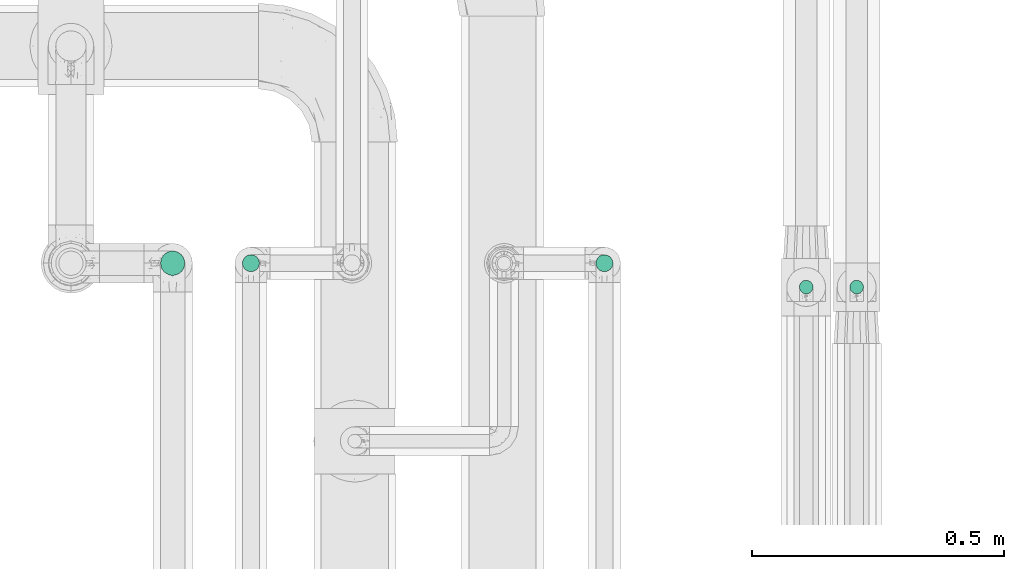
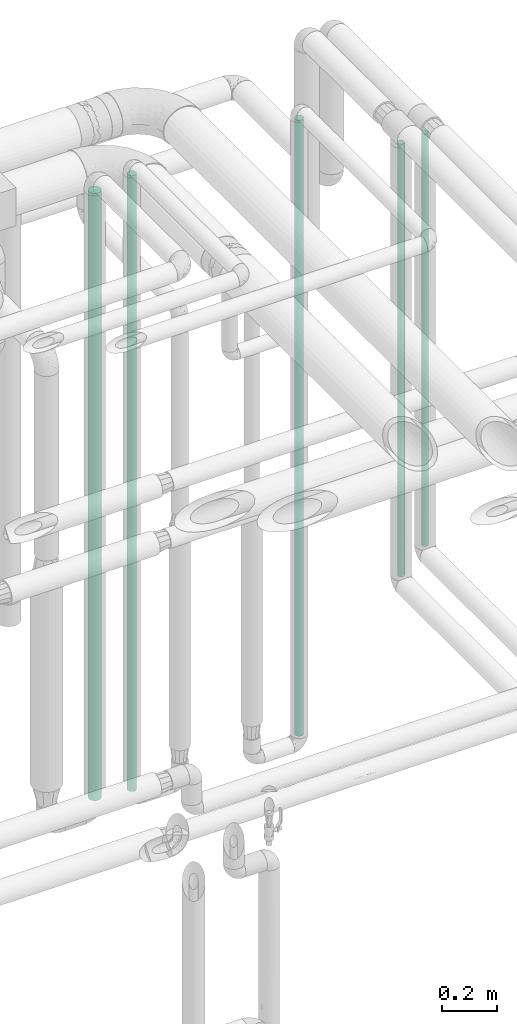
# One storey, part 544 of 827: 5 flow segments.
"""IFC2X3 building model written with IfcOpenShell, lengths in millimetres."""

from ifc_helpers import new_model, entity, si_unit, converted_unit, derived_unit, direction, frame, origin, origin_2d_with_axis, place, context, subcontext, project, spatial, circle, extrude, type_object, element, save


model = new_model("IFC2X3")

# Units and contexts
model_context = context("Model", 3, precision=0.01, world=origin(), true_north=direction((6.12303176911189e-17, 1.0)))
body_context = subcontext(model_context, "Body", "Model", "MODEL_VIEW")
ifc_project = project(units=[si_unit("LENGTHUNIT", "METRE", prefix="MILLI"), si_unit("AREAUNIT", "SQUARE_METRE"), si_unit("VOLUMEUNIT", "CUBIC_METRE"), converted_unit("PLANEANGLEUNIT", "DEGREE", entity("IfcRatioMeasure", 0.0174532925199433), si_unit("PLANEANGLEUNIT", "RADIAN"), dimensions=[0, 0, 0, 0, 0, 0, 0]), si_unit("MASSUNIT", "GRAM", prefix="KILO"), derived_unit("MASSDENSITYUNIT", [(si_unit("MASSUNIT", "GRAM", prefix="KILO"), 1), (si_unit("LENGTHUNIT", "METRE"), -3)]), derived_unit("MOMENTOFINERTIAUNIT", [(si_unit("LENGTHUNIT", "METRE"), 4)]), si_unit("TIMEUNIT", "SECOND"), si_unit("FREQUENCYUNIT", "HERTZ"), si_unit("THERMODYNAMICTEMPERATUREUNIT", "DEGREE_CELSIUS"), derived_unit("THERMALTRANSMITTANCEUNIT", [(si_unit("MASSUNIT", "GRAM", prefix="KILO"), 1), (si_unit("THERMODYNAMICTEMPERATUREUNIT", "KELVIN"), -1), (si_unit("TIMEUNIT", "SECOND"), -3)]), derived_unit("VOLUMETRICFLOWRATEUNIT", [(si_unit("LENGTHUNIT", "METRE"), 3), (si_unit("TIMEUNIT", "SECOND"), -1)]), derived_unit("MASSFLOWRATEUNIT", [(si_unit("MASSUNIT", "GRAM", prefix="KILO"), 1), (si_unit("TIMEUNIT", "SECOND"), -1)]), derived_unit("ROTATIONALFREQUENCYUNIT", [(si_unit("TIMEUNIT", "SECOND"), -1)]), si_unit("ELECTRICCURRENTUNIT", "AMPERE"), si_unit("ELECTRICVOLTAGEUNIT", "VOLT"), si_unit("POWERUNIT", "WATT"), si_unit("FORCEUNIT", "NEWTON", prefix="KILO"), si_unit("ILLUMINANCEUNIT", "LUX"), si_unit("LUMINOUSFLUXUNIT", "LUMEN"), si_unit("LUMINOUSINTENSITYUNIT", "CANDELA"), derived_unit("USERDEFINED", [(si_unit("MASSUNIT", "GRAM", prefix="KILO"), -1), (si_unit("LENGTHUNIT", "METRE"), -2), (si_unit("TIMEUNIT", "SECOND"), 3), (si_unit("LUMINOUSFLUXUNIT", "LUMEN"), 1)]), derived_unit("LINEARVELOCITYUNIT", [(si_unit("LENGTHUNIT", "METRE"), 1), (si_unit("TIMEUNIT", "SECOND"), -1)]), si_unit("PRESSUREUNIT", "PASCAL"), derived_unit("USERDEFINED", [(si_unit("LENGTHUNIT", "METRE"), -2), (si_unit("MASSUNIT", "GRAM", prefix="KILO"), 1), (si_unit("TIMEUNIT", "SECOND"), -2)]), derived_unit("LINEARFORCEUNIT", [(si_unit("MASSUNIT", "GRAM", prefix="KILO"), 1), (si_unit("LENGTHUNIT", "METRE"), 1), (si_unit("TIMEUNIT", "SECOND"), -2), (si_unit("LENGTHUNIT", "METRE"), -1)]), derived_unit("PLANARFORCEUNIT", [(si_unit("MASSUNIT", "GRAM", prefix="KILO"), 1), (si_unit("LENGTHUNIT", "METRE"), 1), (si_unit("TIMEUNIT", "SECOND"), -2), (si_unit("LENGTHUNIT", "METRE"), -2)])], contexts=[model_context])

# Site, building, storey
site_placement = place(None, origin())
site = spatial("IfcSite", under=ifc_project, at=site_placement, CompositionType="ELEMENT")
building_placement = place(site_placement, origin())
building = spatial("IfcBuilding", under=site, at=building_placement, CompositionType="ELEMENT")
storey_placement = place(building_placement, frame((0.0, 0.0, 28200.0)))
storey = spatial("IfcBuildingStorey", under=building, at=storey_placement, Name="08", CompositionType="ELEMENT", Elevation=28200.0)

# Flow segments
pipe_segment_type = type_object("IfcPipeSegmentType", PredefinedType="NOTDEFINED")
flow_segment_1_placement = place(storey_placement, frame((61137.64, 17437.84, 1129.1)))
element("IfcFlowSegment", 1, at=flow_segment_1_placement, inside=storey, type_object=pipe_segment_type, context=body_context, shape_type="SweptSolid", body=[
    extrude(circle(Radius=13.4, at=origin_2d_with_axis()), frame((15.0, 15.0, 0.0), z_axis=(0.0, 0.0, 1.0), x_axis=(-1.0, 0.0, 0.0)), (0.0, 0.0, 1.0), 1822.6431888057),
])
flow_segment_2_placement = place(storey_placement, frame((61037.64, 17437.84, 1029.1)))
element("IfcFlowSegment", 2, at=flow_segment_2_placement, inside=storey, type_object=pipe_segment_type, context=body_context, shape_type="SweptSolid", body=[
    extrude(circle(Radius=13.4, at=origin_2d_with_axis()), frame((15.0, 15.0, 0.0), z_axis=(0.0, 0.0, 1.0), x_axis=(-1.0, 0.0, 0.0)), (1.11444364847557e-09, 0.0, 1.0), 1913.63839645316),
])
for number, where in (
    (3, (60634.79, 17481.65, 438.0)),
    (4, (59934.79, 17481.65, 438.0)),
):
    element("IfcFlowSegment", number, at=place(storey_placement, frame(where)), inside=storey, type_object=pipe_segment_type, context=body_context, shape_type="SweptSolid", body=[
        extrude(circle(Radius=16.75, at=origin_2d_with_axis()), frame((18.35, 18.35, 0.0)), (0.0, 0.0, 1.0), 2724.00000000001),
    ])
flow_segment_3_placement = place(storey_placement, frame((59772.54, 17474.4, 457.0)))
element("IfcFlowSegment", 5, at=flow_segment_3_placement, inside=storey, type_object=pipe_segment_type, context=body_context, shape_type="SweptSolid", body=[
    extrude(circle(Radius=24.0, at=origin_2d_with_axis()), frame((25.6, 25.6, 0.0)), (0.0, 0.0, 1.0), 2686.0),
])

save(model, "model.ifc")
